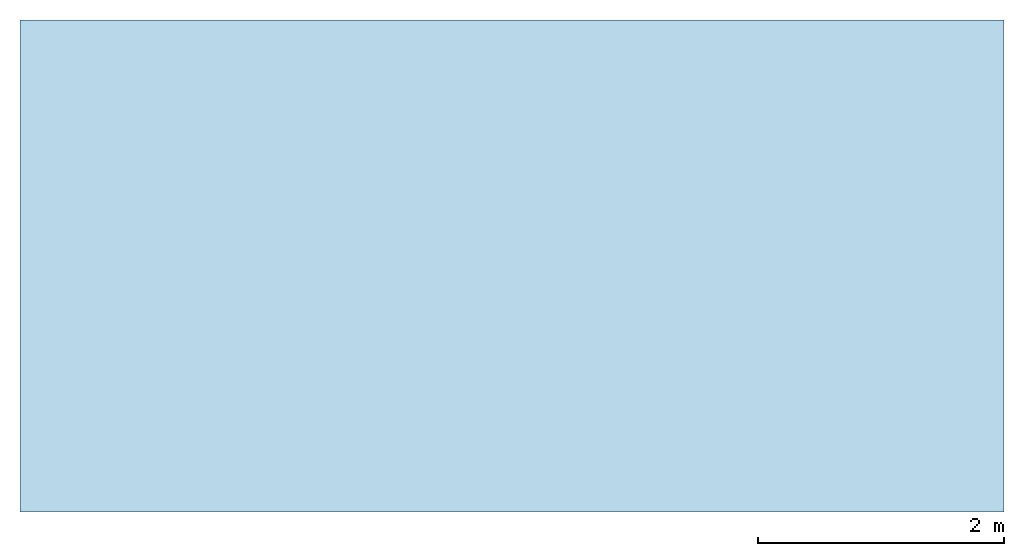
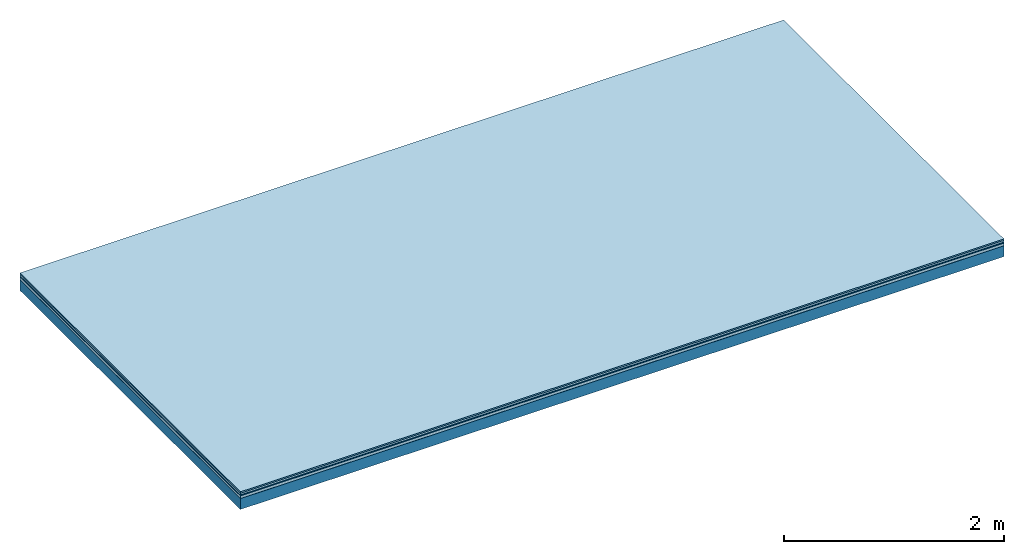
# One storey: 5 plates, 1 member, 1 element without a shape of its own.
"""IFC4 building model written with IfcOpenShell, lengths in metres."""

from ifc_helpers import new_model, si_unit, derived_unit, direction, frame, frame_2d, origin, origin_with_axes, place, context, project, spatial, rectangle, extrude, material, layer, layer_set, type_object, element, aggregate, save


model = new_model("IFC4")

# Units and contexts
plan_context = context("Plan", 3, precision=1e-05, world=origin(), true_north=direction((0.0, 1.0)))
model_context = context("Model", 3, precision=1e-05, world=origin(), true_north=direction((0.0, 1.0)))
ifc_project = project(units=[si_unit("LENGTHUNIT", "METRE"), derived_unit("SOUNDPRESSUREUNIT", [(si_unit("PRESSUREUNIT", "PASCAL", prefix="MICRO"), 0)]), si_unit("ENERGYUNIT", "JOULE", prefix="MEGA"), si_unit("MASSUNIT", "GRAM", prefix="KILO"), derived_unit("THERMALTRANSMITTANCEUNIT", [(si_unit("POWERUNIT", "WATT"), 1), (si_unit("AREAUNIT", "SQUARE_METRE"), -1), (si_unit("THERMODYNAMICTEMPERATUREUNIT", "KELVIN"), -1)]), derived_unit("AREADENSITYUNIT", [(si_unit("MASSUNIT", "GRAM", prefix="KILO"), 1), (si_unit("AREAUNIT", "SQUARE_METRE"), -1)]), derived_unit("USERDEFINED", [(si_unit("ENERGYUNIT", "JOULE", prefix="MEGA"), 1), (si_unit("AREAUNIT", "SQUARE_METRE"), -1)])], contexts=[plan_context, model_context])

# Site, building, storey
site = spatial("IfcSite", under=ifc_project)
building_placement = place(None, origin())
building = spatial("IfcBuilding", under=site, at=building_placement)
storey_placement = place(building_placement, origin())
storey = spatial("IfcBuildingStorey", under=building, at=storey_placement)

# Slab, member, plates
ifc_material_1 = material(Category="11.013")
ifc_layer_1 = layer(ifc_material_1, 0.015, Name="Flooring")
ifc_material_2 = material(Category="03.007")
ifc_layer_2 = layer(ifc_material_2, 0.02, Name="On-material")
ifc_material_3 = material(Name="Wood fiber generic product", Category="10.009")
ifc_layer_3 = layer(ifc_material_3, 0.01, Name="Impact sound insulation")
ifc_material_4 = material(Name="with broken")
ifc_layer_4 = layer(ifc_material_4, 0.03, Name="on Supporting structure")
ifc_material_5 = material(Name="protection", Category="09.007")
ifc_layer_5 = layer(ifc_material_5, 0.0005, Name="Sub-floor")
ifc_material_6 = material(Name="no composite action")
ifc_layer_6 = layer(ifc_material_6, 0.0, Name="Bond")
ifc_layer_7 = layer(None, 0.12, Name="Supporting structure")
ifc_layer_set = layer_set([ifc_layer_1, ifc_layer_2, ifc_layer_3, ifc_layer_4, ifc_layer_5, ifc_layer_6, ifc_layer_7])
slab_type = type_object("IfcSlabType", Name="A2042", PredefinedType="NOTDEFINED", material=ifc_layer_set)
slab_placement = place(None, frame((0.0, 0.0, 0.0), z_axis=(0.0, 0.0, -1.0), x_axis=(1.0, 0.0, 0.0)))
slab = element("IfcSlab", 1, at=slab_placement, inside=storey, type_object=slab_type, material=ifc_layer_set, Name="Slab #1")
ifc_material_7 = material(Name="Solid timber panel")
member_placement = place(slab_placement, origin())
member = element("IfcMember", 2, at=member_placement, material=ifc_material_7, Name="Supporting structure", context=plan_context, shape_type="SweptSolid", body=[
    extrude(rectangle(XDim=1.0, YDim=0.12, at=frame_2d((0.5, 0.06), x_axis=(1.0, 0.0))), frame((0.0, 4.0, 0.0755), z_axis=(0.0, -1.0, 0.0), x_axis=(1.0, 0.0, 0.0)), (0.0, 0.0, 1.0), 4.0),
    extrude(rectangle(XDim=1.0, YDim=0.12, at=frame_2d((0.5, 0.06), x_axis=(1.0, 0.0))), frame((1.0, 4.0, 0.0755), z_axis=(0.0, -1.0, 0.0), x_axis=(1.0, 0.0, 0.0)), (0.0, 0.0, 1.0), 4.0),
    extrude(rectangle(XDim=1.0, YDim=0.12, at=frame_2d((0.5, 0.06), x_axis=(1.0, 0.0))), frame((2.0, 4.0, 0.0755), z_axis=(0.0, -1.0, 0.0), x_axis=(1.0, 0.0, 0.0)), (0.0, 0.0, 1.0), 4.0),
    extrude(rectangle(XDim=1.0, YDim=0.12, at=frame_2d((0.5, 0.06), x_axis=(1.0, 0.0))), frame((3.0, 4.0, 0.0755), z_axis=(0.0, -1.0, 0.0), x_axis=(1.0, 0.0, 0.0)), (0.0, 0.0, 1.0), 4.0),
    extrude(rectangle(XDim=1.0, YDim=0.12, at=frame_2d((0.5, 0.06), x_axis=(1.0, 0.0))), frame((4.0, 4.0, 0.0755), z_axis=(0.0, -1.0, 0.0), x_axis=(1.0, 0.0, 0.0)), (0.0, 0.0, 1.0), 4.0),
    extrude(rectangle(XDim=1.0, YDim=0.12, at=frame_2d((0.5, 0.06), x_axis=(1.0, 0.0))), frame((5.0, 4.0, 0.0755), z_axis=(0.0, -1.0, 0.0), x_axis=(1.0, 0.0, 0.0)), (0.0, 0.0, 1.0), 4.0),
    extrude(rectangle(XDim=1.0, YDim=0.12, at=frame_2d((0.5, 0.06), x_axis=(1.0, 0.0))), frame((6.0, 4.0, 0.0755), z_axis=(0.0, -1.0, 0.0), x_axis=(1.0, 0.0, 0.0)), (0.0, 0.0, 1.0), 4.0),
    extrude(rectangle(XDim=1.0, YDim=0.12, at=frame_2d((0.5, 0.06), x_axis=(1.0, 0.0))), frame((7.0, 4.0, 0.0755), z_axis=(0.0, -1.0, 0.0), x_axis=(1.0, 0.0, 0.0)), (0.0, 0.0, 1.0), 4.0),
])
plate_1_placement = place(slab_placement, origin())
plate_1 = element("IfcPlate", 3, at=plate_1_placement, material=ifc_material_1, Name="Flooring", context=plan_context, shape_type="SweptSolid", body=[
    extrude(rectangle(XDim=8.0, YDim=4.0, at=frame_2d((4.0, 2.0), x_axis=(1.0, 0.0))), origin_with_axes(), (0.0, 0.0, 1.0), 0.015),
])
plate_2_placement = place(slab_placement, origin())
plate_2 = element("IfcPlate", 4, at=plate_2_placement, material=ifc_material_2, Name="On-material", context=plan_context, shape_type="SweptSolid", body=[
    extrude(rectangle(XDim=8.0, YDim=4.0, at=frame_2d((4.0, 2.0), x_axis=(1.0, 0.0))), frame((0.0, 0.0, 0.015), z_axis=(0.0, 0.0, 1.0), x_axis=(1.0, 0.0, 0.0)), (0.0, 0.0, 1.0), 0.02),
])
plate_3_placement = place(slab_placement, origin())
plate_3 = element("IfcPlate", 5, at=plate_3_placement, material=ifc_material_3, Name="Impact sound insulation", context=plan_context, shape_type="SweptSolid", body=[
    extrude(rectangle(XDim=8.0, YDim=4.0, at=frame_2d((4.0, 2.0), x_axis=(1.0, 0.0))), frame((0.0, 0.0, 0.035), z_axis=(0.0, 0.0, 1.0), x_axis=(1.0, 0.0, 0.0)), (0.0, 0.0, 1.0), 0.01),
])
plate_4_placement = place(slab_placement, origin())
plate_4 = element("IfcPlate", 6, at=plate_4_placement, material=ifc_material_4, Name="on Supporting structure", context=plan_context, shape_type="SweptSolid", body=[
    extrude(rectangle(XDim=8.0, YDim=4.0, at=frame_2d((4.0, 2.0), x_axis=(1.0, 0.0))), frame((0.0, 0.0, 0.045), z_axis=(0.0, 0.0, 1.0), x_axis=(1.0, 0.0, 0.0)), (0.0, 0.0, 1.0), 0.03),
])
plate_5_placement = place(slab_placement, origin())
plate_5 = element("IfcPlate", 7, at=plate_5_placement, material=ifc_material_5, Name="Sub-floor", context=plan_context, shape_type="SweptSolid", body=[
    extrude(rectangle(XDim=8.0, YDim=4.0, at=frame_2d((4.0, 2.0), x_axis=(1.0, 0.0))), frame((0.0, 0.0, 0.075), z_axis=(0.0, 0.0, 1.0), x_axis=(1.0, 0.0, 0.0)), (0.0, 0.0, 1.0), 0.0005),
])
aggregate(slab, [plate_1, plate_2, plate_3, plate_4, plate_5, member])

save(model, "model.ifc")
